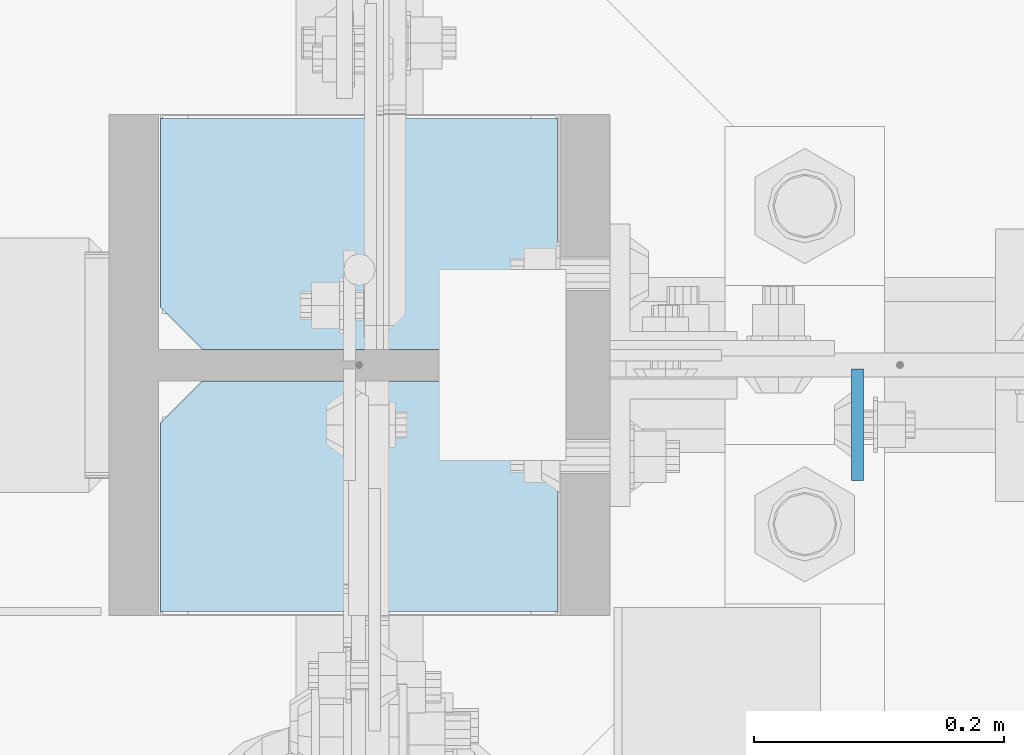
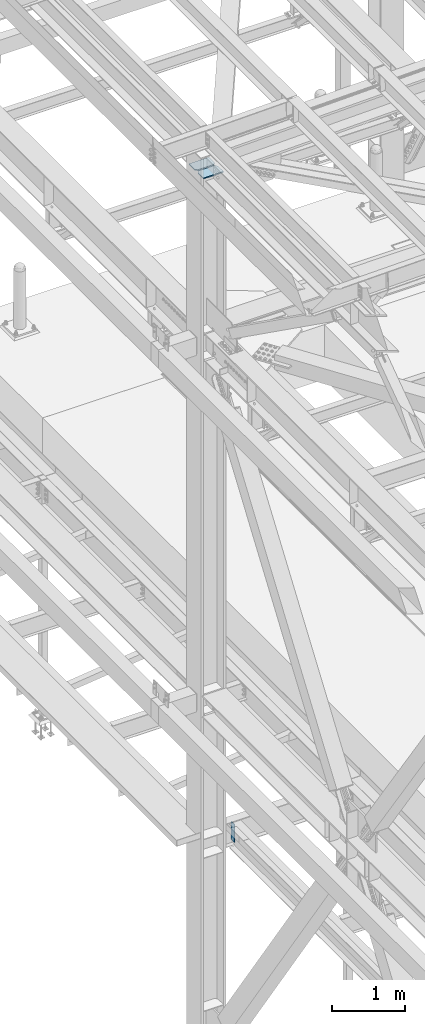
# One storey, part 3364 of 3843: 3 plates, 2 elements without a shape of their own.
"""IFC2X3 building model written with IfcOpenShell, lengths in millimetres."""

from ifc_helpers import new_model, si_unit, frame, origin_with_axes, place, context, subcontext, project, spatial, faceted_brep, material, type_object, element, aggregate, save


model = new_model("IFC2X3")

# Units and contexts
model_context = context("Model", 3, precision=1e-05, world=origin_with_axes())
body_context = subcontext(model_context, "Body", "Model", "MODEL_VIEW")
ifc_project = project(units=[si_unit("LENGTHUNIT", "METRE", prefix="MILLI"), si_unit("AREAUNIT", "SQUARE_METRE"), si_unit("VOLUMEUNIT", "CUBIC_METRE"), si_unit("MASSUNIT", "GRAM", prefix="KILO"), si_unit("TIMEUNIT", "SECOND"), si_unit("PLANEANGLEUNIT", "RADIAN"), si_unit("SOLIDANGLEUNIT", "STERADIAN"), si_unit("THERMODYNAMICTEMPERATUREUNIT", "DEGREE_CELSIUS"), si_unit("LUMINOUSINTENSITYUNIT", "LUMEN")], contexts=[model_context])

# Site, building, storey
site_placement = place(None, origin_with_axes())
site = spatial("IfcSite", under=ifc_project, at=site_placement, CompositionType="ELEMENT")
building_placement = place(site_placement, origin_with_axes())
building = spatial("IfcBuilding", under=site, at=building_placement, Name="Undefined", CompositionType="ELEMENT")
storey_placement = place(building_placement, origin_with_axes())
storey = spatial("IfcBuildingStorey", under=building, at=storey_placement, Name="Undefined", CompositionType="ELEMENT", Elevation=0.0)

# Assembly, plate
assembly_1_placement = place(storey_placement, origin_with_axes())
assembly_1 = element("IfcElementAssembly", 1, at=assembly_1_placement, inside=storey, Name="BEAM", AssemblyPlace="NOTDEFINED", PredefinedType="RIGID_FRAME")
ifc_material = material(Name="STEEL/A572-50")
plate_type_1 = type_object("IfcPlateType", PredefinedType="NOTDEFINED")
plate_1_placement = place(assembly_1_placement, frame((36973.66875, 75625.325, 33997.9), z_axis=(0.0, -1.0, 0.0), x_axis=(0.0, 0.0, -1.0)))
plate_1 = element("IfcPlate", 2, at=plate_1_placement, type_object=plate_type_1, material=ifc_material, Name="PLATE", context=body_context, shape_type="Brep", body=[
    faceted_brep([(0.0, -4.76249999999709, 0.0), (0.0, -4.76249999999709, 88.9000015258789), (0.0, 4.76249999999709, 88.9000015258789), (0.0, 4.76249999999709, 0.0), (304.800000000003, -4.76249999999709, 88.8999999999942), (304.800000000003, 4.76249999999709, 88.8999999999942), (304.800000000003, -4.76249999999709, 0.0), (304.800000000003, 4.76249999999709, 0.0)], [[[0, 1, 2, 3]], [[1, 4, 5, 2]], [[4, 6, 7, 5]], [[6, 0, 3, 7]], [[5, 7, 3, 2]], [[6, 4, 1, 0]]]),
])
aggregate(assembly_1, [plate_1])

# Assembly, plates
assembly_2_placement = place(storey_placement, origin_with_axes())
assembly_2 = element("IfcElementAssembly", 3, at=assembly_2_placement, inside=storey, Name="COLUMN", AssemblyPlace="NOTDEFINED", PredefinedType="RIGID_FRAME")
plate_type_2 = type_object("IfcPlateType", PredefinedType="NOTDEFINED")
plate_2_placement = place(assembly_2_placement, frame((36734.75, 75825.35, 45059.5999999998), z_axis=(-1.0, 0.0, 0.0), x_axis=(0.0, -1.0, 0.0)))
plate_2 = element("IfcPlate", 4, at=plate_2_placement, type_object=plate_type_2, material=ifc_material, Name="PLATE", context=body_context, shape_type="Brep", body=[
    faceted_brep([(0.0, -9.52500000000146, 0.0), (0.0, -9.52500000000146, 317.5), (0.0, 9.52500000000146, 317.5), (0.0, 9.52500000000146, 0.0), (150.81249847413, -9.52500000000146, 317.5), (150.81249847413, 9.52500000000146, 317.5), (184.150000000009, -9.52500000000146, 284.162498474121), (184.150000000009, 9.52500000000146, 284.162498474121), (184.150000000009, -9.52500000000146, 33.3375015258789), (184.150000000009, 9.52500000000146, 33.3375015258789), (150.81249847413, -9.52500000000146, 0.0), (150.81249847413, 9.52500000000146, 0.0)], [[[0, 1, 2, 3]], [[1, 4, 5, 2]], [[4, 6, 7, 5]], [[6, 8, 9, 7]], [[8, 10, 11, 9]], [[10, 0, 3, 11]], [[5, 7, 9, 11, 3, 2]], [[10, 8, 6, 4, 1, 0]]]),
])
plate_3_placement = place(assembly_2_placement, frame((36417.25, 75431.65, 45059.5999999883), z_axis=(1.0, 0.0, 0.0), x_axis=(0.0, 1.0, 0.0)))
plate_3 = element("IfcPlate", 5, at=plate_3_placement, type_object=plate_type_2, material=ifc_material, Name="PLATE", context=body_context, shape_type="Brep", body=[
    faceted_brep([(0.0, -9.52500000000146, 0.0), (0.0, -9.52500000000146, 317.5), (0.0, 9.52500000000146, 317.5), (0.0, 9.52500000000146, 0.0), (150.81249847413, -9.52500000000146, 317.5), (150.81249847413, 9.52500000000146, 317.5), (184.150000000009, -9.52500000000146, 284.162498474121), (184.150000000009, 9.52500000000146, 284.162498474121), (184.150000000009, -9.52500000000146, 33.3375015258789), (184.150000000009, 9.52500000000146, 33.3375015258789), (150.81249847413, -9.52500000000146, 0.0), (150.81249847413, 9.52500000000146, 0.0)], [[[0, 1, 2, 3]], [[1, 4, 5, 2]], [[4, 6, 7, 5]], [[6, 8, 9, 7]], [[8, 10, 11, 9]], [[10, 0, 3, 11]], [[5, 7, 9, 11, 3, 2]], [[10, 8, 6, 4, 1, 0]]]),
])
aggregate(assembly_2, [plate_2, plate_3])

save(model, "model.ifc")
